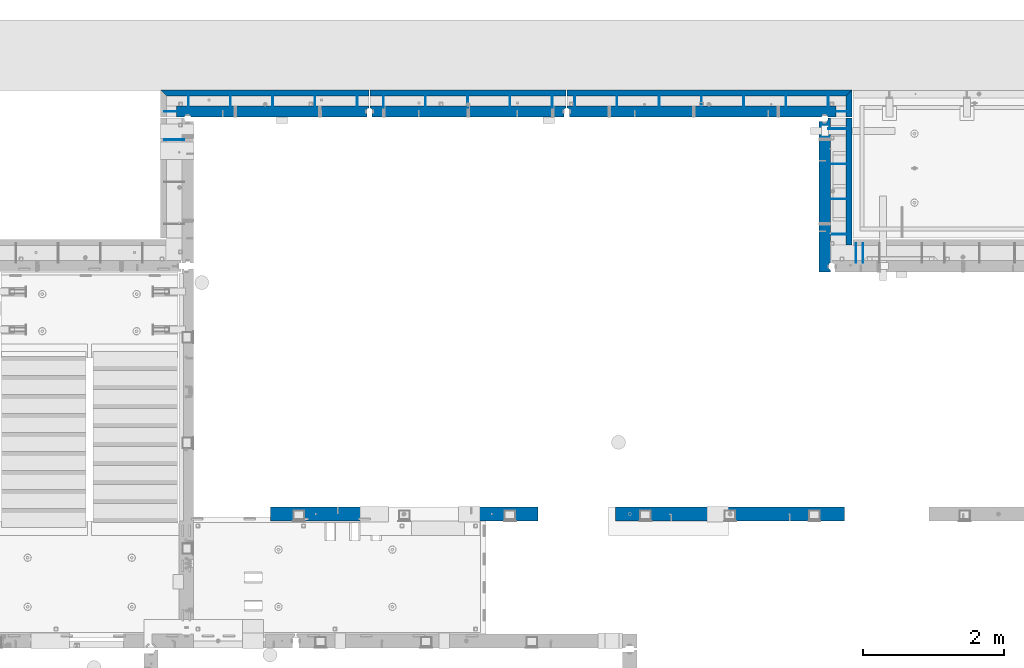
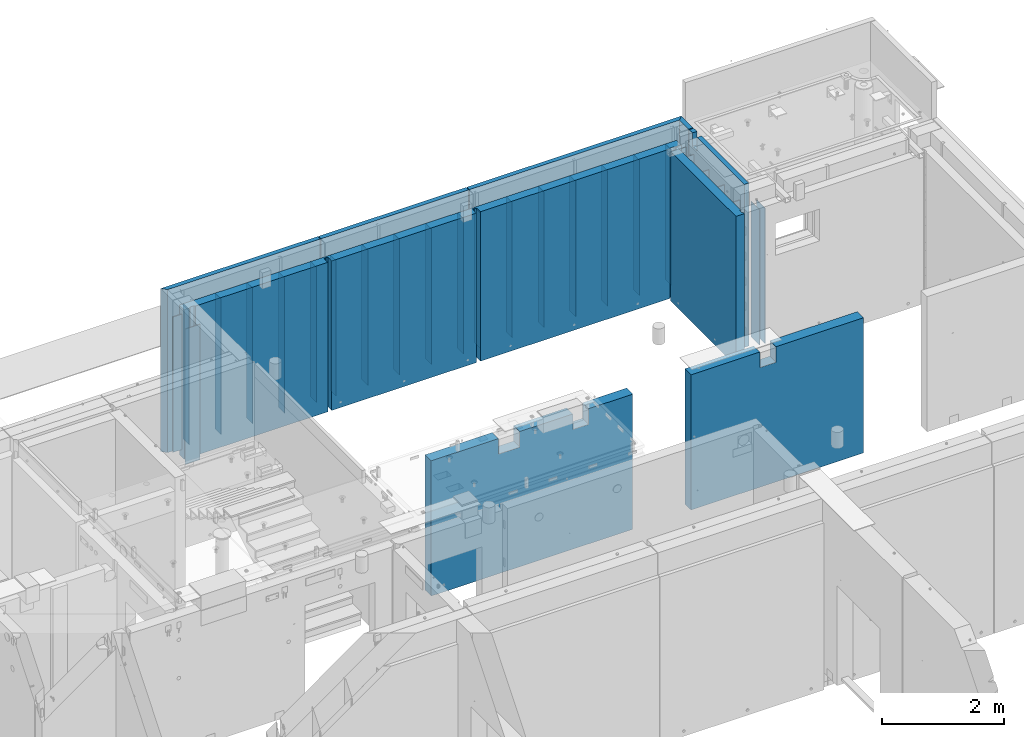
# One storey, part 177 of 264: 37 walls, 8 elements without a shape of their own.
"""IFC2X3 building model written with IfcOpenShell, lengths in millimetres."""

from ifc_helpers import new_model, si_unit, frame, origin_with_axes, place, context, subcontext, project, spatial, faceted_brep, material, type_object, element, aggregate, save


model = new_model("IFC2X3")

# Units and contexts
model_context = context("Model", 3, precision=1e-05, world=origin_with_axes())
body_context = subcontext(model_context, "Body", "Model", "MODEL_VIEW")
ifc_project = project(units=[si_unit("LENGTHUNIT", "METRE", prefix="MILLI"), si_unit("AREAUNIT", "SQUARE_METRE"), si_unit("VOLUMEUNIT", "CUBIC_METRE"), si_unit("MASSUNIT", "GRAM", prefix="KILO"), si_unit("TIMEUNIT", "SECOND"), si_unit("PLANEANGLEUNIT", "RADIAN"), si_unit("SOLIDANGLEUNIT", "STERADIAN"), si_unit("THERMODYNAMICTEMPERATUREUNIT", "DEGREE_CELSIUS"), si_unit("LUMINOUSINTENSITYUNIT", "LUMEN")], contexts=[model_context])

# Site, building, storey
site_placement = place(None, origin_with_axes())
site = spatial("IfcSite", under=ifc_project, at=site_placement, CompositionType="ELEMENT")
building_placement = place(site_placement, origin_with_axes())
building = spatial("IfcBuilding", under=site, at=building_placement, CompositionType="ELEMENT")
storey_placement = place(building_placement, origin_with_axes())
storey = spatial("IfcBuildingStorey", under=building, at=storey_placement, Name="K", CompositionType="ELEMENT", Elevation=0.0)

# Assembly, walls
assembly_1_placement = place(storey_placement, origin_with_axes())
assembly_1 = element("IfcElementAssembly", 1, at=assembly_1_placement, inside=storey, AssemblyPlace="NOTDEFINED", PredefinedType="REINFORCEMENT_UNIT")
ifc_material_1 = material(Name="Undefined")
wall_type_1 = type_object("IfcWallType", PredefinedType="NOTDEFINED")
wall_1_placement = place(assembly_1_placement, frame((31824.9902441406, 20549.9951872276, 79990.0), z_axis=(0.0, 0.0, 1.0), x_axis=(0.0, 1.0, 0.0)))
wall_1 = element("IfcWall", 2, at=wall_1_placement, type_object=wall_type_1, material=ifc_material_1, Name="(PD)", context=body_context, shape_type="Brep", body=[
    faceted_brep([(0.0, 5.0, -1350.0), (0.0, 5.0, 1350.0), (280.0, 5.0, 1350.0), (280.0, 5.0, -1350.0), (0.0, -5.0, 1350.0), (280.0, -5.0, 1350.0), (0.0, -5.0, -1350.0), (280.0, -5.0, -1350.0)], [[[0, 1, 2, 3]], [[1, 4, 5, 2]], [[4, 6, 7, 5]], [[6, 0, 3, 7]], [[5, 7, 3, 2]], [[6, 4, 1, 0]]]),
])
wall_2_placement = place(assembly_1_placement, frame((31924.9902441406, 20549.9951872276, 79990.0), z_axis=(0.0, 0.0, 1.0), x_axis=(0.0, 1.0, 0.0)))
wall_2 = element("IfcWall", 3, at=wall_2_placement, type_object=wall_type_1, material=ifc_material_1, Name="(PD)", context=body_context, shape_type="Brep", body=[
    faceted_brep([(0.0, 5.0, -1350.0), (0.0, 5.0, 1350.0), (280.0, 5.0, 1350.0), (280.0, 5.0, -1350.0), (0.0, -5.0, 1350.0), (280.0, -5.0, 1350.0), (0.0, -5.0, -1350.0), (280.0, -5.0, -1350.0)], [[[0, 1, 2, 3]], [[1, 4, 5, 2]], [[4, 6, 7, 5]], [[6, 0, 3, 7]], [[5, 7, 3, 2]], [[6, 4, 1, 0]]]),
])
aggregate(assembly_1, [wall_1, wall_2])

# Assembly, wall
assembly_2_placement = place(storey_placement, origin_with_axes())
assembly_2 = element("IfcElementAssembly", 4, at=assembly_2_placement, inside=storey, AssemblyPlace="NOTDEFINED", PredefinedType="REINFORCEMENT_UNIT")
wall_3_placement = place(assembly_2_placement, frame((22280.0033032291, 22299.9956621903, 79990.0), z_axis=(0.0, 0.0, 1.0), x_axis=(-1.0, 3.00000001838171e-08, 0.0)))
wall_3 = element("IfcWall", 5, at=wall_3_placement, type_object=wall_type_1, material=ifc_material_1, Name="(PD)", context=body_context, shape_type="Brep", body=[
    faceted_brep([(0.0, 5.0, -1350.0), (0.0, 5.0, 1350.0), (280.0, 5.0, 1350.0), (280.0, 5.0, -1350.0), (0.0, -5.0, 1350.0), (280.0, -5.0, 1350.0), (0.0, -5.0, -1350.0), (280.0, -5.0, -1350.0)], [[[0, 1, 2, 3]], [[1, 4, 5, 2]], [[4, 6, 7, 5]], [[6, 0, 3, 7]], [[5, 7, 3, 2]], [[6, 4, 1, 0]]]),
])
aggregate(assembly_2, [wall_3])

# Assembly, walls
assembly_3_placement = place(storey_placement, origin_with_axes())
assembly_3 = element("IfcElementAssembly", 6, at=assembly_3_placement, inside=storey, AssemblyPlace="NOTDEFINED", PredefinedType="REINFORCEMENT_UNIT")
wall_4_placement = place(assembly_3_placement, frame((31429.9922865001, 20955.0044042285, 79990.0), z_axis=(0.0, 0.0, 1.0), x_axis=(1.0, 0.0, 0.0)))
wall_4 = element("IfcWall", 7, at=wall_4_placement, type_object=wall_type_1, material=ifc_material_1, Name="(PD)", context=body_context, shape_type="Brep", body=[
    faceted_brep([(0.0, 5.0, -1350.0), (0.0, 5.0, 1350.0), (280.0, 5.0, 1350.0), (280.0, 5.0, -1350.0), (0.0, -5.0, 1350.0), (280.0, -5.0, 1350.0), (0.0, -5.0, -1350.0), (280.0, -5.0, -1350.0)], [[[0, 1, 2, 3]], [[1, 4, 5, 2]], [[4, 6, 7, 5]], [[6, 0, 3, 7]], [[5, 7, 3, 2]], [[6, 4, 1, 0]]]),
])
wall_5_placement = place(assembly_3_placement, frame((31429.9922865001, 21455.0044042285, 79990.0), z_axis=(0.0, 0.0, 1.0), x_axis=(1.0, 0.0, 0.0)))
wall_5 = element("IfcWall", 8, at=wall_5_placement, type_object=wall_type_1, material=ifc_material_1, Name="(PD)", context=body_context, shape_type="Brep", body=[
    faceted_brep([(0.0, 5.0, -1350.0), (0.0, 5.0, 1350.0), (280.0, 5.0, 1350.0), (280.0, 5.0, -1350.0), (0.0, -5.0, 1350.0), (280.0, -5.0, 1350.0), (0.0, -5.0, -1350.0), (280.0, -5.0, -1350.0)], [[[0, 1, 2, 3]], [[1, 4, 5, 2]], [[4, 6, 7, 5]], [[6, 0, 3, 7]], [[5, 7, 3, 2]], [[6, 4, 1, 0]]]),
])
wall_6_placement = place(assembly_3_placement, frame((31429.9922865001, 21955.0044042285, 79990.0), z_axis=(0.0, 0.0, 1.0), x_axis=(1.0, 0.0, 0.0)))
wall_6 = element("IfcWall", 9, at=wall_6_placement, type_object=wall_type_1, material=ifc_material_1, Name="(PD)", context=body_context, shape_type="Brep", body=[
    faceted_brep([(0.0, 5.0, -1350.0), (0.0, 5.0, 1350.0), (280.0, 5.0, 1350.0), (280.0, 5.0, -1350.0), (0.0, -5.0, 1350.0), (280.0, -5.0, 1350.0), (0.0, -5.0, -1350.0), (280.0, -5.0, -1350.0)], [[[0, 1, 2, 3]], [[1, 4, 5, 2]], [[4, 6, 7, 5]], [[6, 0, 3, 7]], [[5, 7, 3, 2]], [[6, 4, 1, 0]]]),
])
wall_7_placement = place(assembly_3_placement, frame((31429.9922865001, 22455.0044042285, 79990.0), z_axis=(0.0, 0.0, 1.0), x_axis=(1.0, 0.0, 0.0)))
wall_7 = element("IfcWall", 10, at=wall_7_placement, type_object=wall_type_1, material=ifc_material_1, Name="(PD)", context=body_context, shape_type="Brep", body=[
    faceted_brep([(0.0, 5.0, -1350.0), (0.0, 5.0, 1350.0), (280.0, 5.0, 1350.0), (280.0, 5.0, -1350.0), (0.0, -5.0, 1350.0), (280.0, -5.0, 1350.0), (0.0, -5.0, -1350.0), (280.0, -5.0, -1350.0)], [[[0, 1, 2, 3]], [[1, 4, 5, 2]], [[4, 6, 7, 5]], [[6, 0, 3, 7]], [[5, 7, 3, 2]], [[6, 4, 1, 0]]]),
])

assembly_4_placement = place(storey_placement, origin_with_axes())
assembly_4 = element("IfcElementAssembly", 11, at=assembly_4_placement, inside=storey, AssemblyPlace="NOTDEFINED", PredefinedType="REINFORCEMENT_UNIT")
wall_8_placement = place(assembly_4_placement, frame((31709.9933032306, 22699.9956697503, 79990.0), z_axis=(0.0, 0.0, 1.0), x_axis=(-1.0, 3.00000001838171e-08, 0.0)))
wall_8 = element("IfcWall", 12, at=wall_8_placement, type_object=wall_type_1, material=ifc_material_1, Name="(PD)", context=body_context, shape_type="Brep", body=[
    faceted_brep([(0.0, 5.0, -1350.0), (0.0, 5.0, 1350.0), (200.000000000127, 5.0, 1350.0), (200.000000000127, 5.0, -1350.0), (0.0, -5.0, 1350.0), (200.000000000127, -5.0, 1350.0), (0.0, -5.0, -1350.0), (200.000000000127, -5.0, -1350.0)], [[[0, 1, 2, 3]], [[1, 4, 5, 2]], [[4, 6, 7, 5]], [[6, 0, 3, 7]], [[5, 7, 3, 2]], [[6, 4, 1, 0]]]),
])
wall_9_placement = place(assembly_4_placement, frame((31429.9962472027, 22749.9961131486, 79990.0), z_axis=(0.0, 0.0, 1.0), x_axis=(0.0, 1.0, 0.0)))
wall_9 = element("IfcWall", 13, at=wall_9_placement, type_object=wall_type_1, material=ifc_material_1, Name="(PD)", context=body_context, shape_type="Brep", body=[
    faceted_brep([(0.0, 5.0, -1350.0), (0.0, 5.0, 1350.0), (200.000000000127, 5.0, 1350.0), (200.000000000127, 5.0, -1350.0), (0.0, -5.0, 1350.0), (200.000000000127, -5.0, 1350.0), (0.0, -5.0, -1350.0), (200.000000000127, -5.0, -1350.0)], [[[0, 1, 2, 3]], [[1, 4, 5, 2]], [[4, 6, 7, 5]], [[6, 0, 3, 7]], [[5, 7, 3, 2]], [[6, 4, 1, 0]]]),
])
wall_10_placement = place(assembly_4_placement, frame((30829.9962472027, 22749.9961131486, 79990.0), z_axis=(0.0, 0.0, 1.0), x_axis=(0.0, 1.0, 0.0)))
wall_10 = element("IfcWall", 14, at=wall_10_placement, type_object=wall_type_1, material=ifc_material_1, Name="(PD)", context=body_context, shape_type="Brep", body=[
    faceted_brep([(0.0, 5.0, -1350.0), (0.0, 5.0, 1350.0), (200.000000000127, 5.0, 1350.0), (200.000000000127, 5.0, -1350.0), (0.0, -5.0, 1350.0), (200.000000000127, -5.0, 1350.0), (0.0, -5.0, -1350.0), (200.000000000127, -5.0, -1350.0)], [[[0, 1, 2, 3]], [[1, 4, 5, 2]], [[4, 6, 7, 5]], [[6, 0, 3, 7]], [[5, 7, 3, 2]], [[6, 4, 1, 0]]]),
])
wall_11_placement = place(assembly_4_placement, frame((30229.9962472027, 22749.9961131486, 79990.0), z_axis=(0.0, 0.0, 1.0), x_axis=(0.0, 1.0, 0.0)))
wall_11 = element("IfcWall", 15, at=wall_11_placement, type_object=wall_type_1, material=ifc_material_1, Name="(PD)", context=body_context, shape_type="Brep", body=[
    faceted_brep([(0.0, 5.0, -1350.0), (0.0, 5.0, 1350.0), (200.000000000127, 5.0, 1350.0), (200.000000000127, 5.0, -1350.0), (0.0, -5.0, 1350.0), (200.000000000127, -5.0, 1350.0), (0.0, -5.0, -1350.0), (200.000000000127, -5.0, -1350.0)], [[[0, 1, 2, 3]], [[1, 4, 5, 2]], [[4, 6, 7, 5]], [[6, 0, 3, 7]], [[5, 7, 3, 2]], [[6, 4, 1, 0]]]),
])
wall_12_placement = place(assembly_4_placement, frame((29629.9962472027, 22749.9961131486, 79990.0), z_axis=(0.0, 0.0, 1.0), x_axis=(0.0, 1.0, 0.0)))
wall_12 = element("IfcWall", 16, at=wall_12_placement, type_object=wall_type_1, material=ifc_material_1, Name="(PD)", context=body_context, shape_type="Brep", body=[
    faceted_brep([(0.0, 5.0, -1350.0), (0.0, 5.0, 1350.0), (200.000000000127, 5.0, 1350.0), (200.000000000127, 5.0, -1350.0), (0.0, -5.0, 1350.0), (200.000000000127, -5.0, 1350.0), (0.0, -5.0, -1350.0), (200.000000000127, -5.0, -1350.0)], [[[0, 1, 2, 3]], [[1, 4, 5, 2]], [[4, 6, 7, 5]], [[6, 0, 3, 7]], [[5, 7, 3, 2]], [[6, 4, 1, 0]]]),
])
wall_13_placement = place(assembly_4_placement, frame((29029.9962472027, 22749.9961131486, 79990.0), z_axis=(0.0, 0.0, 1.0), x_axis=(0.0, 1.0, 0.0)))
wall_13 = element("IfcWall", 17, at=wall_13_placement, type_object=wall_type_1, material=ifc_material_1, Name="(PD)", context=body_context, shape_type="Brep", body=[
    faceted_brep([(0.0, 5.0, -1350.0), (0.0, 5.0, 1350.0), (200.000000000127, 5.0, 1350.0), (200.000000000127, 5.0, -1350.0), (0.0, -5.0, 1350.0), (200.000000000127, -5.0, 1350.0), (0.0, -5.0, -1350.0), (200.000000000127, -5.0, -1350.0)], [[[0, 1, 2, 3]], [[1, 4, 5, 2]], [[4, 6, 7, 5]], [[6, 0, 3, 7]], [[5, 7, 3, 2]], [[6, 4, 1, 0]]]),
])
wall_14_placement = place(assembly_4_placement, frame((28429.9962472027, 22749.9961131486, 79990.0), z_axis=(0.0, 0.0, 1.0), x_axis=(0.0, 1.0, 0.0)))
wall_14 = element("IfcWall", 18, at=wall_14_placement, type_object=wall_type_1, material=ifc_material_1, Name="(PD)", context=body_context, shape_type="Brep", body=[
    faceted_brep([(0.0, 5.0, -1350.0), (0.0, 5.0, 1350.0), (200.000000000127, 5.0, 1350.0), (200.000000000127, 5.0, -1350.0), (0.0, -5.0, 1350.0), (200.000000000127, -5.0, 1350.0), (0.0, -5.0, -1350.0), (200.000000000127, -5.0, -1350.0)], [[[0, 1, 2, 3]], [[1, 4, 5, 2]], [[4, 6, 7, 5]], [[6, 0, 3, 7]], [[5, 7, 3, 2]], [[6, 4, 1, 0]]]),
])
wall_15_placement = place(assembly_4_placement, frame((27829.9962472027, 22749.9961131486, 79990.0), z_axis=(0.0, 0.0, 1.0), x_axis=(0.0, 1.0, 0.0)))
wall_15 = element("IfcWall", 19, at=wall_15_placement, type_object=wall_type_1, material=ifc_material_1, Name="(PD)", context=body_context, shape_type="Brep", body=[
    faceted_brep([(0.0, 5.0, -1350.0), (0.0, 5.0, 1350.0), (200.000000000127, 5.0, 1350.0), (200.000000000127, 5.0, -1350.0), (0.0, -5.0, 1350.0), (200.000000000127, -5.0, 1350.0), (0.0, -5.0, -1350.0), (200.000000000127, -5.0, -1350.0)], [[[0, 1, 2, 3]], [[1, 4, 5, 2]], [[4, 6, 7, 5]], [[6, 0, 3, 7]], [[5, 7, 3, 2]], [[6, 4, 1, 0]]]),
])

assembly_5_placement = place(storey_placement, origin_with_axes())
assembly_5 = element("IfcElementAssembly", 20, at=assembly_5_placement, inside=storey, AssemblyPlace="NOTDEFINED", PredefinedType="REINFORCEMENT_UNIT")
wall_16_placement = place(assembly_5_placement, frame((27509.9962472027, 22749.9961131486, 79990.0), z_axis=(0.0, 0.0, 1.0), x_axis=(0.0, 1.0, 0.0)))
wall_16 = element("IfcWall", 21, at=wall_16_placement, type_object=wall_type_1, material=ifc_material_1, Name="(PD)", context=body_context, shape_type="Brep", body=[
    faceted_brep([(0.0, 5.0, -1350.0), (0.0, 5.0, 1350.0), (200.000000000127, 5.0, 1350.0), (200.000000000127, 5.0, -1350.0), (0.0, -5.0, 1350.0), (200.000000000127, -5.0, 1350.0), (0.0, -5.0, -1350.0), (200.000000000127, -5.0, -1350.0)], [[[0, 1, 2, 3]], [[1, 4, 5, 2]], [[4, 6, 7, 5]], [[6, 0, 3, 7]], [[5, 7, 3, 2]], [[6, 4, 1, 0]]]),
])
wall_17_placement = place(assembly_5_placement, frame((26909.9962472027, 22749.9961131486, 79990.0), z_axis=(0.0, 0.0, 1.0), x_axis=(0.0, 1.0, 0.0)))
wall_17 = element("IfcWall", 22, at=wall_17_placement, type_object=wall_type_1, material=ifc_material_1, Name="(PD)", context=body_context, shape_type="Brep", body=[
    faceted_brep([(0.0, 5.0, -1350.0), (0.0, 5.0, 1350.0), (200.000000000127, 5.0, 1350.0), (200.000000000127, 5.0, -1350.0), (0.0, -5.0, 1350.0), (200.000000000127, -5.0, 1350.0), (0.0, -5.0, -1350.0), (200.000000000127, -5.0, -1350.0)], [[[0, 1, 2, 3]], [[1, 4, 5, 2]], [[4, 6, 7, 5]], [[6, 0, 3, 7]], [[5, 7, 3, 2]], [[6, 4, 1, 0]]]),
])
wall_18_placement = place(assembly_5_placement, frame((26309.9962472027, 22749.9961131486, 79990.0), z_axis=(0.0, 0.0, 1.0), x_axis=(0.0, 1.0, 0.0)))
wall_18 = element("IfcWall", 23, at=wall_18_placement, type_object=wall_type_1, material=ifc_material_1, Name="(PD)", context=body_context, shape_type="Brep", body=[
    faceted_brep([(0.0, 5.0, -1350.0), (0.0, 5.0, 1350.0), (200.000000000127, 5.0, 1350.0), (200.000000000127, 5.0, -1350.0), (0.0, -5.0, 1350.0), (200.000000000127, -5.0, 1350.0), (0.0, -5.0, -1350.0), (200.000000000127, -5.0, -1350.0)], [[[0, 1, 2, 3]], [[1, 4, 5, 2]], [[4, 6, 7, 5]], [[6, 0, 3, 7]], [[5, 7, 3, 2]], [[6, 4, 1, 0]]]),
])
wall_19_placement = place(assembly_5_placement, frame((25709.9962472027, 22749.9961131486, 79990.0), z_axis=(0.0, 0.0, 1.0), x_axis=(0.0, 1.0, 0.0)))
wall_19 = element("IfcWall", 24, at=wall_19_placement, type_object=wall_type_1, material=ifc_material_1, Name="(PD)", context=body_context, shape_type="Brep", body=[
    faceted_brep([(0.0, 5.0, -1350.0), (0.0, 5.0, 1350.0), (200.000000000127, 5.0, 1350.0), (200.000000000127, 5.0, -1350.0), (0.0, -5.0, 1350.0), (200.000000000127, -5.0, 1350.0), (0.0, -5.0, -1350.0), (200.000000000127, -5.0, -1350.0)], [[[0, 1, 2, 3]], [[1, 4, 5, 2]], [[4, 6, 7, 5]], [[6, 0, 3, 7]], [[5, 7, 3, 2]], [[6, 4, 1, 0]]]),
])
wall_20_placement = place(assembly_5_placement, frame((25109.9962472027, 22749.9961131486, 79990.0), z_axis=(0.0, 0.0, 1.0), x_axis=(0.0, 1.0, 0.0)))
wall_20 = element("IfcWall", 25, at=wall_20_placement, type_object=wall_type_1, material=ifc_material_1, Name="(PD)", context=body_context, shape_type="Brep", body=[
    faceted_brep([(0.0, 5.0, -1350.0), (0.0, 5.0, 1350.0), (200.000000000127, 5.0, 1350.0), (200.000000000127, 5.0, -1350.0), (0.0, -5.0, 1350.0), (200.000000000127, -5.0, 1350.0), (0.0, -5.0, -1350.0), (200.000000000127, -5.0, -1350.0)], [[[0, 1, 2, 3]], [[1, 4, 5, 2]], [[4, 6, 7, 5]], [[6, 0, 3, 7]], [[5, 7, 3, 2]], [[6, 4, 1, 0]]]),
])

assembly_6_placement = place(storey_placement, origin_with_axes())
assembly_6 = element("IfcElementAssembly", 26, at=assembly_6_placement, inside=storey, AssemblyPlace="NOTDEFINED", PredefinedType="REINFORCEMENT_UNIT")
wall_21_placement = place(assembly_6_placement, frame((24739.9962472027, 22749.9961131486, 79990.0), z_axis=(0.0, 0.0, 1.0), x_axis=(0.0, 1.0, 0.0)))
wall_21 = element("IfcWall", 27, at=wall_21_placement, type_object=wall_type_1, material=ifc_material_1, Name="(PD)", context=body_context, shape_type="Brep", body=[
    faceted_brep([(0.0, 5.0, -1350.0), (0.0, 5.0, 1350.0), (200.000000000127, 5.0, 1350.0), (200.000000000127, 5.0, -1350.0), (0.0, -5.0, 1350.0), (200.000000000127, -5.0, 1350.0), (0.0, -5.0, -1350.0), (200.000000000127, -5.0, -1350.0)], [[[0, 1, 2, 3]], [[1, 4, 5, 2]], [[4, 6, 7, 5]], [[6, 0, 3, 7]], [[5, 7, 3, 2]], [[6, 4, 1, 0]]]),
])
wall_22_placement = place(assembly_6_placement, frame((24139.9962472027, 22749.9961131486, 79990.0), z_axis=(0.0, 0.0, 1.0), x_axis=(0.0, 1.0, 0.0)))
wall_22 = element("IfcWall", 28, at=wall_22_placement, type_object=wall_type_1, material=ifc_material_1, Name="(PD)", context=body_context, shape_type="Brep", body=[
    faceted_brep([(0.0, 5.0, -1350.0), (0.0, 5.0, 1350.0), (200.000000000127, 5.0, 1350.0), (200.000000000127, 5.0, -1350.0), (0.0, -5.0, 1350.0), (200.000000000127, -5.0, 1350.0), (0.0, -5.0, -1350.0), (200.000000000127, -5.0, -1350.0)], [[[0, 1, 2, 3]], [[1, 4, 5, 2]], [[4, 6, 7, 5]], [[6, 0, 3, 7]], [[5, 7, 3, 2]], [[6, 4, 1, 0]]]),
])
wall_23_placement = place(assembly_6_placement, frame((23539.9962472027, 22749.9961131486, 79990.0), z_axis=(0.0, 0.0, 1.0), x_axis=(0.0, 1.0, 0.0)))
wall_23 = element("IfcWall", 29, at=wall_23_placement, type_object=wall_type_1, material=ifc_material_1, Name="(PD)", context=body_context, shape_type="Brep", body=[
    faceted_brep([(0.0, 5.0, -1350.0), (0.0, 5.0, 1350.0), (200.000000000127, 5.0, 1350.0), (200.000000000127, 5.0, -1350.0), (0.0, -5.0, 1350.0), (200.000000000127, -5.0, 1350.0), (0.0, -5.0, -1350.0), (200.000000000127, -5.0, -1350.0)], [[[0, 1, 2, 3]], [[1, 4, 5, 2]], [[4, 6, 7, 5]], [[6, 0, 3, 7]], [[5, 7, 3, 2]], [[6, 4, 1, 0]]]),
])
wall_24_placement = place(assembly_6_placement, frame((22939.9962472027, 22749.9961131486, 79990.0), z_axis=(0.0, 0.0, 1.0), x_axis=(0.0, 1.0, 0.0)))
wall_24 = element("IfcWall", 30, at=wall_24_placement, type_object=wall_type_1, material=ifc_material_1, Name="(PD)", context=body_context, shape_type="Brep", body=[
    faceted_brep([(0.0, 5.0, -1350.0), (0.0, 5.0, 1350.0), (200.000000000127, 5.0, 1350.0), (200.000000000127, 5.0, -1350.0), (0.0, -5.0, 1350.0), (200.000000000127, -5.0, 1350.0), (0.0, -5.0, -1350.0), (200.000000000127, -5.0, -1350.0)], [[[0, 1, 2, 3]], [[1, 4, 5, 2]], [[4, 6, 7, 5]], [[6, 0, 3, 7]], [[5, 7, 3, 2]], [[6, 4, 1, 0]]]),
])
wall_25_placement = place(assembly_6_placement, frame((22200.0033032291, 22699.9956697503, 79990.0), z_axis=(0.0, 0.0, 1.0), x_axis=(-1.0, 3.00000001838171e-08, 0.0)))
wall_25 = element("IfcWall", 31, at=wall_25_placement, type_object=wall_type_1, material=ifc_material_1, Name="(PD)", context=body_context, shape_type="Brep", body=[
    faceted_brep([(0.0, 5.0, -1350.0), (0.0, 5.0, 1350.0), (200.000000000127, 5.0, 1350.0), (200.000000000127, 5.0, -1350.0), (0.0, -5.0, 1350.0), (200.000000000127, -5.0, 1350.0), (0.0, -5.0, -1350.0), (200.000000000127, -5.0, -1350.0)], [[[0, 1, 2, 3]], [[1, 4, 5, 2]], [[4, 6, 7, 5]], [[6, 0, 3, 7]], [[5, 7, 3, 2]], [[6, 4, 1, 0]]]),
])
wall_26_placement = place(assembly_6_placement, frame((22339.9962472027, 22749.9961131486, 79990.0), z_axis=(0.0, 0.0, 1.0), x_axis=(0.0, 1.0, 0.0)))
wall_26 = element("IfcWall", 32, at=wall_26_placement, type_object=wall_type_1, material=ifc_material_1, Name="(PD)", context=body_context, shape_type="Brep", body=[
    faceted_brep([(0.0, 5.0, -1350.0), (0.0, 5.0, 1350.0), (200.000000000127, 5.0, 1350.0), (200.000000000127, 5.0, -1350.0), (0.0, -5.0, 1350.0), (200.000000000127, -5.0, 1350.0), (0.0, -5.0, -1350.0), (200.000000000127, -5.0, -1350.0)], [[[0, 1, 2, 3]], [[1, 4, 5, 2]], [[4, 6, 7, 5]], [[6, 0, 3, 7]], [[5, 7, 3, 2]], [[6, 4, 1, 0]]]),
])

# Wall
ifc_material_2 = material(Name="CONCRETE/C30/37")
wall_type_2 = type_object("IfcWallType", PredefinedType="NOTDEFINED")
wall_27_placement = place(assembly_5_placement, frame((24919.9998417669, 22962.5000000004, 80115.0), z_axis=(0.0, 0.0, 1.0), x_axis=(1.0, 0.0, 0.0)))
wall_27 = element("IfcWall", 33, at=wall_27_placement, type_object=wall_type_2, material=ifc_material_2, context=body_context, shape_type="Brep", body=[
    faceted_brep([(0.0, 42.5000000000036, -1625.0), (0.0, 42.5000000000036, 1625.0), (2784.99635412073, 42.5000000000036, 1625.0), (2784.99635412073, 42.5000000000036, -1625.0), (3.63797880709171e-12, -42.4999999999964, 1625.0), (2784.99635412074, -42.4999999999964, 1625.0), (3.63797880709171e-12, -42.4999999999964, -1625.0), (2784.99635412074, -42.4999999999964, -1625.0)], [[[0, 1, 2, 3]], [[1, 4, 5, 2]], [[4, 6, 7, 5]], [[6, 0, 3, 7]], [[5, 7, 3, 2]], [[6, 4, 1, 0]]]),
])

wall_28_placement = place(assembly_6_placement, frame((21944.9994055291, 22962.5, 80115.0), z_axis=(0.0, 0.0, 1.0), x_axis=(1.0, 0.0, 0.0)))
wall_28 = element("IfcWall", 34, at=wall_28_placement, type_object=wall_type_2, material=ifc_material_2, context=body_context, shape_type="Brep", body=[
    faceted_brep([(0.0, 42.5000000000036, -1625.0), (0.0, 42.5000000000036, 1625.0), (2960.00056592515, 42.5, 1625.0), (2960.00056592515, 42.5, -1625.0), (85.0, -42.5, 1625.0), (2960.00056592515, -42.5, 1625.0), (85.0, -42.5, -1625.0), (2960.00056592515, -42.5, -1625.0)], [[[0, 1, 2, 3]], [[1, 4, 5, 2]], [[4, 6, 7, 5]], [[6, 0, 3, 7]], [[5, 7, 3, 2]], [[6, 4, 1, 0]]]),
])

wall_29_placement = place(assembly_4_placement, frame((31722.4962317246, 23005.0012711778, 80115.0), z_axis=(0.0, 0.0, 1.0), x_axis=(0.0, -1.0, 0.0)))
wall_29 = element("IfcWall", 35, at=wall_29_placement, type_object=wall_type_2, material=ifc_material_2, context=body_context, shape_type="Brep", body=[
    faceted_brep([(385.0, -42.5, 1625.0), (385.0, -42.5, -1625.0), (385.0, 42.5, -1625.0), (385.0, 42.5, 1625.0), (0.0, 42.5000000000036, 1625.0), (85.0, -42.5, 1625.0), (85.0, -42.5, -1625.0), (0.0, 42.5000000000036, -1625.0)], [[[0, 1, 2, 3]], [[0, 3, 4, 5]], [[1, 0, 5, 6]], [[2, 1, 6, 7]], [[3, 2, 7, 4]], [[6, 5, 4, 7]]]),
])

wall_30_placement = place(assembly_4_placement, frame((27719.999904092, 22962.5000023861, 80115.0), z_axis=(0.0, 0.0, 1.0), x_axis=(1.0, 0.0, 0.0)))
wall_30 = element("IfcWall", 36, at=wall_30_placement, type_object=wall_type_2, material=ifc_material_2, context=body_context, shape_type="Brep", body=[
    faceted_brep([(0.0, 42.5000000000036, -1625.0), (0.0, 42.5000000000036, 1625.0), (4044.99634110447, 42.5, 1625.0), (4044.99634110447, 42.5, -1625.0), (3.63797880709171e-12, -42.4999999999964, 1625.0), (3959.99634106772, -42.4999999999964, 1625.0), (3.63797880709171e-12, -42.4999999999964, -1625.0), (3959.99634106772, -42.4999999999964, -1625.0)], [[[0, 1, 2, 3]], [[1, 4, 5, 2]], [[4, 6, 7, 5]], [[6, 0, 3, 7]], [[5, 7, 3, 2]], [[6, 4, 1, 0]]]),
])

wall_31_placement = place(assembly_3_placement, frame((31722.4963458486, 22605.0010488316, 80115.0), z_axis=(0.0, 0.0, 1.0), x_axis=(0.0, -1.0, 0.0)))
wall_31 = element("IfcWall", 37, at=wall_31_placement, type_object=wall_type_2, material=ifc_material_2, context=body_context, shape_type="Brep", body=[
    faceted_brep([(254.980663399783, 42.5, 1625.0), (254.980663399783, 42.5, 1355.0), (254.980708449784, -42.4999999999964, 1355.0), (254.980708449784, -42.5, 1625.0), (104.980632882187, 42.5, 1355.0), (104.980677932188, -42.4999999999964, 1355.0), (104.980632882187, 42.5, 1625.0), (104.980677932188, -42.5, 1625.0), (1800.00126747966, -42.4999999999964, 1625.0), (1800.00126747966, -42.4999999999964, -1625.0), (1800.00126747967, 42.5, -1625.0), (1800.00126747967, 42.5, 1625.0), (3.63797880709171e-12, -42.4999999999964, -1625.0), (0.0, 42.5000000000036, -1625.0), (3.63797880709171e-12, -42.4999999999964, 1625.0), (0.0, 42.5000000000036, 1625.0)], [[[0, 1, 2, 3]], [[4, 5, 2, 1]], [[6, 7, 5, 4]], [[8, 9, 10, 11]], [[12, 13, 10, 9]], [[12, 14, 15, 13]], [[1, 0, 11, 10, 13, 15, 6, 4]], [[8, 11, 0, 3]], [[14, 12, 9, 8, 3, 2, 5, 7]], [[15, 14, 7, 6]]]),
])

ifc_material_3 = material(Name="CONCRETE/C25/30")
wall_type_3 = type_object("IfcWallType", PredefinedType="NOTDEFINED")
wall_32_placement = place(assembly_5_placement, frame((24919.9999630525, 22700.0, 79980.0), z_axis=(0.0, 0.0, 1.0), x_axis=(1.0, 0.0, 0.0)))
wall_32 = element("IfcWall", 38, at=wall_32_placement, type_object=wall_type_3, material=ifc_material_3, context=body_context, shape_type="Brep", body=[
    faceted_brep([(2756.24818253607, -80.0, 1490.0), (2756.24818253607, -80.0, -1490.0), (2756.24818288707, 36.9987099730133, -1490.0), (2756.24818288707, 36.9987099730133, 1490.00000000001), (2784.99635379843, 49.4562505988324, 1490.0), (2784.99635379843, 49.4562505988324, -1490.0), (30.0000356667078, 36.9999861402212, 1490.0), (30.0000356667078, 36.9999861402212, -1490.0), (29.9999816127165, -80.0, -1490.0), (29.9999816127165, -80.0, 1490.0), (0.0, 50.0000180584211, 1490.0), (0.0, 50.0000180584211, -1490.0), (3.63797880709171e-12, 80.0000000000036, 1490.0), (3.63797880709171e-12, 80.0000000000036, -1490.0), (2784.99635379843, 80.0000000000036, 1490.0), (2784.99635379843, 80.0000000000036, -1490.0)], [[[0, 1, 2, 3]], [[4, 3, 2, 5]], [[6, 7, 8, 9]], [[10, 11, 7, 6]], [[12, 13, 11, 10]], [[13, 12, 14, 15]], [[15, 14, 4, 5]], [[1, 8, 7, 11, 13, 15, 5, 2]], [[9, 8, 1, 0]], [[14, 12, 10, 6, 9, 0, 3, 4]]]),
])

aggregate(assembly_5, [wall_16, wall_17, wall_18, wall_19, wall_20, wall_27, wall_32])

wall_33_placement = place(assembly_3_placement, frame((31379.9963537981, 22620.0012491151, 79980.0), z_axis=(0.0, 0.0, 1.0), x_axis=(0.0, -1.0, 0.0)))
wall_33 = element("IfcWall", 39, at=wall_33_placement, type_object=wall_type_3, material=ifc_material_3, context=body_context, shape_type="Brep", body=[
    faceted_brep([(65.0000551797493, 37.0000550561017, 1490.0), (65.0000551797493, 37.0000550561017, -1490.0), (65.0001542787977, -80.0, -1490.0), (65.0001542787977, -80.0, 1490.0), (15.0000694699011, 49.9999920500995, 1490.0), (15.0000694699011, 49.9999920500995, -1490.0), (2200.00120671537, -79.9999999999964, 1490.0), (2200.00120671537, -79.9999999999964, -1490.0), (2200.00120671538, 80.0, -1490.0), (2200.00120671538, 80.0, 1490.0), (2170.0012067154, 80.0, -1490.0), (2170.0012067154, 80.0, 1490.0), (2157.00120671541, 60.0000000000218, -1490.0), (2157.00120671541, 60.0000000000218, 1490.0), (2083.00120671541, 60.0000000000255, -1490.0), (2083.00120671541, 60.0000000000255, 1490.0), (2070.00120671543, 80.0, 1490.0), (2070.00120671543, 80.0, -1490.0), (15.0000187587248, 80.0, -1490.0), (15.0000187587248, 80.0, 1490.0)], [[[0, 1, 2, 3]], [[4, 5, 1, 0]], [[6, 7, 8, 9]], [[9, 8, 10, 11]], [[11, 10, 12, 13]], [[13, 12, 14, 15]], [[16, 15, 14, 17]], [[18, 19, 16, 17]], [[3, 6, 9, 11, 13, 15, 16, 19, 4, 0]], [[7, 6, 3, 2]], [[18, 17, 14, 12, 10, 8, 7, 2, 1, 5]], [[19, 18, 5, 4]]]),
])

aggregate(assembly_3, [wall_4, wall_5, wall_6, wall_7, wall_31, wall_33])

wall_34_placement = place(assembly_4_placement, frame((27712.4999746086, 22700.0, 79980.0), z_axis=(0.0, 0.0, 1.0), x_axis=(1.0, 0.0, 0.0)))
wall_34 = element("IfcWall", 40, at=wall_34_placement, type_object=wall_type_3, material=ifc_material_3, context=body_context, shape_type="Brep", body=[
    faceted_brep([(38.748165966299, 37.0000055048586, 1490.0), (38.748165966299, 37.0000055048586, -1490.0), (38.7481825803006, -79.9999999999964, -1490.0), (38.7481825803006, -79.9999999999964, 1490.0), (7.50000000000364, 50.5408721531312, 1490.0), (7.50000000000364, 50.5408721531312, -1490.0), (7.50000000000728, 80.0000000000036, -1490.0), (7.50000000000728, 80.0000000000036, 1490.0), (3827.49635379833, 80.0000000000073, 1490.0), (3827.49635379833, 80.0000000000073, -1490.0), (3827.49635379833, -79.9999999999964, 1490.0), (3827.49635379833, -79.9999999999964, -1490.0), (3717.49635382973, -79.9999999999927, 1490.0), (3717.49635382973, -79.9999999999927, -1490.0), (3704.4963538297, -59.9999999999527, 1490.0), (3704.4963538297, -59.9999999999527, -1490.0), (3630.4963538297, -59.9999999999527, 1490.0), (3630.4963538297, -59.9999999999527, -1490.0), (3617.49635382967, -79.9999999999964, 1490.0), (3617.49635382967, -79.9999999999964, -1490.0)], [[[0, 1, 2, 3]], [[4, 5, 1, 0]], [[6, 7, 8, 9]], [[10, 11, 9, 8]], [[11, 10, 12, 13]], [[12, 14, 15, 13]], [[16, 17, 15, 14]], [[18, 19, 17, 16]], [[19, 18, 3, 2]], [[6, 9, 11, 13, 15, 17, 19, 2, 1, 5]], [[7, 6, 5, 4]], [[18, 16, 14, 12, 10, 8, 7, 4, 0, 3]]]),
])

aggregate(assembly_4, [wall_8, wall_9, wall_10, wall_11, wall_12, wall_13, wall_14, wall_15, wall_29, wall_30, wall_34])

wall_35_placement = place(assembly_6_placement, frame((22169.9994055291, 22700.0, 79980.0), z_axis=(0.0, 0.0, 1.0), x_axis=(1.0, 0.0, 0.0)))
wall_35 = element("IfcWall", 41, at=wall_35_placement, type_object=wall_type_3, material=ifc_material_3, context=body_context, shape_type="Brep", body=[
    faceted_brep([(2705.00057609607, -80.0, 1490.0), (2705.00057609607, -80.0, -1490.0), (2705.00057609607, 37.0000000000109, -1490.0), (2705.00057609607, 37.0000000000109, 1490.0), (2735.00057609607, 50.0000000000109, 1490.0), (2735.00057609607, 50.0000000000109, -1490.0), (210.0, -80.0, 1490.0), (197.0, -60.0, 1490.0), (197.0, -60.0, -1490.0), (210.0, -80.0, -1490.0), (123.0, -60.0, 1490.0), (123.0, -60.0, -1490.0), (110.0, -80.0, 1490.0), (110.0, -80.0, -1490.0), (0.0, -80.0, 1490.0), (0.0, -80.0, -1490.0), (3.63797880709171e-12, 80.0000000000036, 1490.0), (3.63797880709171e-12, 80.0000000000036, -1490.0), (2735.00057609607, 80.0, 1490.0), (2735.00057609607, 80.0, -1490.0)], [[[0, 1, 2, 3]], [[4, 3, 2, 5]], [[6, 7, 8, 9]], [[10, 11, 8, 7]], [[12, 13, 11, 10]], [[14, 15, 13, 12]], [[15, 14, 16, 17]], [[17, 16, 18, 19]], [[19, 18, 4, 5]], [[1, 9, 8, 11, 13, 15, 17, 19, 5, 2]], [[6, 9, 1, 0]], [[18, 16, 14, 12, 10, 7, 6, 0, 3, 4]]]),
])

aggregate(assembly_6, [wall_21, wall_22, wall_23, wall_24, wall_25, wall_26, wall_28, wall_35])

# Assembly, wall
assembly_7_placement = place(storey_placement, origin_with_axes())
assembly_7 = element("IfcElementAssembly", 42, at=assembly_7_placement, inside=storey, AssemblyPlace="NOTDEFINED", PredefinedType="REINFORCEMENT_UNIT")
wall_type_4 = type_object("IfcWallType", PredefinedType="NOTDEFINED")
wall_36_placement = place(assembly_7_placement, frame((28410.0014364077, 16980.0, 80122.5), z_axis=(0.0, 0.0, 1.0), x_axis=(1.0, 0.0, 0.0)))
wall_36 = element("IfcWall", 43, at=wall_36_placement, type_object=wall_type_4, material=ifc_material_3, context=body_context, shape_type="Brep", body=[
    faceted_brep([(1299.99948861582, 100.0, 1347.5), (1299.99948861582, -100.0, 1347.5), (1299.99948861582, -100.0, 1037.5), (1299.99948861582, 100.0, 1037.5), (1599.99948861582, -100.0, 1037.5), (1599.99948861582, 100.0, 1037.5), (1599.99948861582, 100.0, 1347.5), (1599.99948861582, -100.0, 1347.5), (0.0, -100.0, -1347.5), (0.0, -100.0, 1347.5), (0.0, 100.0, 1347.5), (0.0, 100.0, -1347.5), (3249.99847412109, 100.0, -1347.5), (3249.99847412109, -100.0, -1347.5), (3249.99847412109, -100.0, 1347.5), (3249.99847412109, 100.0, 1347.5)], [[[0, 1, 2, 3]], [[3, 2, 4, 5]], [[6, 5, 4, 7]], [[8, 9, 10, 11]], [[8, 11, 12, 13]], [[14, 13, 12, 15]], [[14, 15, 6, 7]], [[2, 1, 9, 8, 13, 14, 7, 4]], [[10, 9, 1, 0]], [[15, 12, 11, 10, 0, 3, 5, 6]]]),
])
aggregate(assembly_7, [wall_36])

assembly_8_placement = place(storey_placement, origin_with_axes())
assembly_8 = element("IfcElementAssembly", 44, at=assembly_8_placement, inside=storey, AssemblyPlace="NOTDEFINED", PredefinedType="REINFORCEMENT_UNIT")
wall_37_placement = place(assembly_8_placement, frame((23510.0, 16980.0, 80122.5), z_axis=(0.0, 0.0, 1.0), x_axis=(1.0, 0.0, 0.0)))
wall_37 = element("IfcWall", 45, at=wall_37_placement, type_object=wall_type_4, material=ifc_material_3, context=body_context, shape_type="Brep", body=[
    faceted_brep([(1270.00003665686, 100.0, 1347.5), (1270.00003665686, -100.0, 1347.5), (1270.00003665686, -100.0, 1037.5), (1270.00003665686, 100.0, 1037.5), (1670.00003665686, -100.0, 1037.5), (1670.00003665686, 100.0, 1037.5), (1670.00003665686, 100.0, 1347.5), (1670.00003665686, -100.0, 1347.5), (0.0, -100.0, -1347.5), (0.0, -100.0, 1347.5), (0.0, 100.0, 1347.5), (0.0, 100.0, -1347.5), (3800.00067346828, 100.0, -1347.5), (3800.00067346828, -100.0, -1347.5), (3800.00067346828, -100.0, 1347.5), (3800.00067346828, 100.0, 1347.5), (2970.00003665686, 100.0, 1347.5), (2970.00003665686, -100.0, 1347.5), (2970.00003665686, 100.0, 1037.5), (2970.00003665686, -100.0, 1037.5), (2670.00003665686, 100.0, 1037.5), (2670.00003665686, -100.0, 1037.5), (2670.00003665686, 100.0, 1347.5), (2670.00003665686, -100.0, 1347.5)], [[[0, 1, 2, 3]], [[3, 2, 4, 5]], [[6, 5, 4, 7]], [[8, 9, 10, 11]], [[8, 11, 12, 13]], [[14, 13, 12, 15]], [[14, 15, 16, 17]], [[16, 18, 19, 17]], [[20, 21, 19, 18]], [[22, 23, 21, 20]], [[23, 22, 6, 7]], [[2, 1, 9, 8, 13, 14, 17, 19, 21, 23, 7, 4]], [[10, 9, 1, 0]], [[22, 20, 18, 16, 15, 12, 11, 10, 0, 3, 5, 6]]]),
])
aggregate(assembly_8, [wall_37])

save(model, "model.ifc")
